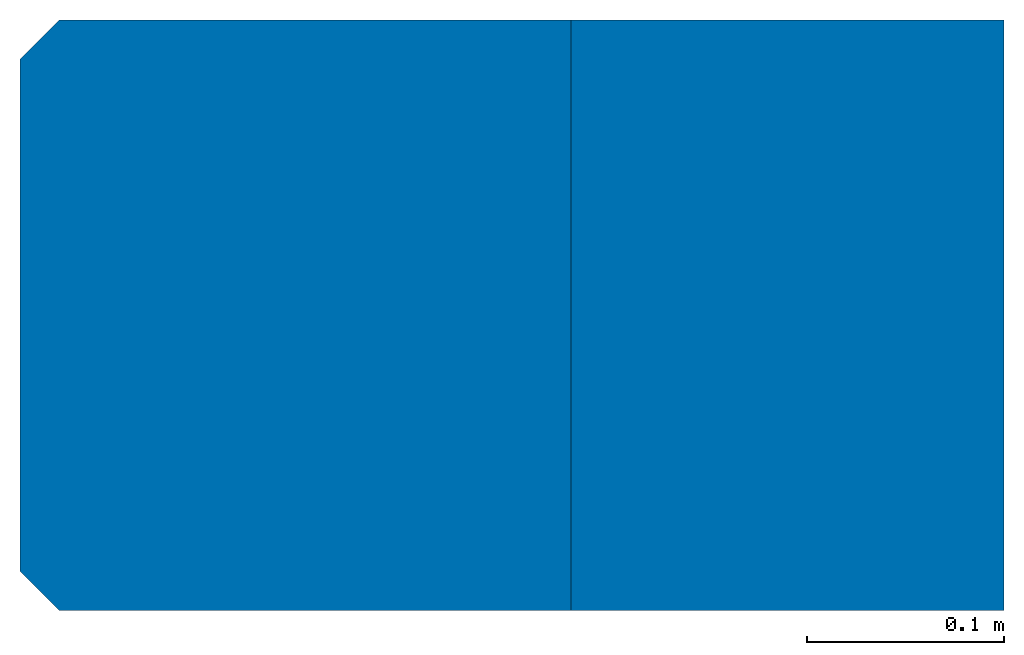
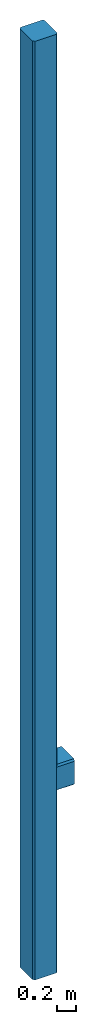
# One storey: 2 columns.
"""IFC2X3 building model written with IfcOpenShell, lengths in metres."""

from ifc_helpers import new_model, entity, si_unit, converted_unit, derived_unit, direction, frame, frame_2d, origin, place, context, subcontext, project, spatial, polyline, rectangle, outline, extrude, clip, halfspace, source, transform, mapped, type_object, type_shapes, element, save


model = new_model("IFC2X3")

# Units and contexts
model_context = context("Model", 3, precision=1e-05, world=origin(), true_north=direction((6.12303176911189e-17, 1.0)))
body_context = subcontext(model_context, "Body", "Model", "MODEL_VIEW")
ifc_project = project(units=[si_unit("LENGTHUNIT", "METRE"), converted_unit("AREAUNIT", "SQUARE FOOT", entity("IfcRatioMeasure", 0.09290304), si_unit("AREAUNIT", "SQUARE_METRE"), dimensions=[2, 0, 0, 0, 0, 0, 0]), converted_unit("VOLUMEUNIT", "CUBIC FOOT", entity("IfcRatioMeasure", 0.028316846592), si_unit("VOLUMEUNIT", "CUBIC_METRE"), dimensions=[3, 0, 0, 0, 0, 0, 0]), converted_unit("PLANEANGLEUNIT", "DEGREE", entity("IfcRatioMeasure", 0.0174532925199433), si_unit("PLANEANGLEUNIT", "RADIAN"), dimensions=[0, 0, 0, 0, 0, 0, 0]), si_unit("MASSUNIT", "GRAM", prefix="KILO"), derived_unit("MASSDENSITYUNIT", [(si_unit("MASSUNIT", "GRAM", prefix="KILO"), 1), (si_unit("LENGTHUNIT", "METRE"), -3)]), si_unit("TIMEUNIT", "SECOND"), si_unit("FREQUENCYUNIT", "HERTZ"), si_unit("THERMODYNAMICTEMPERATUREUNIT", "DEGREE_CELSIUS"), derived_unit("THERMALTRANSMITTANCEUNIT", [(si_unit("MASSUNIT", "GRAM", prefix="KILO"), 1), (si_unit("THERMODYNAMICTEMPERATUREUNIT", "KELVIN"), -1), (si_unit("TIMEUNIT", "SECOND"), -3)]), derived_unit("VOLUMETRICFLOWRATEUNIT", [(si_unit("LENGTHUNIT", "METRE"), 3), (si_unit("TIMEUNIT", "SECOND"), -1)]), si_unit("ELECTRICCURRENTUNIT", "AMPERE"), si_unit("ELECTRICVOLTAGEUNIT", "VOLT"), si_unit("POWERUNIT", "WATT"), si_unit("FORCEUNIT", "NEWTON"), si_unit("ILLUMINANCEUNIT", "LUX"), si_unit("LUMINOUSFLUXUNIT", "LUMEN"), si_unit("LUMINOUSINTENSITYUNIT", "CANDELA"), derived_unit("USERDEFINED", [(si_unit("MASSUNIT", "GRAM", prefix="KILO"), -1), (si_unit("LENGTHUNIT", "METRE"), -2), (si_unit("TIMEUNIT", "SECOND"), 3), (si_unit("LUMINOUSFLUXUNIT", "LUMEN"), 1)]), derived_unit("LINEARVELOCITYUNIT", [(si_unit("LENGTHUNIT", "METRE"), 1), (si_unit("TIMEUNIT", "SECOND"), -1)]), si_unit("PRESSUREUNIT", "PASCAL"), derived_unit("USERDEFINED", [(si_unit("LENGTHUNIT", "METRE"), -2), (si_unit("MASSUNIT", "GRAM", prefix="KILO"), 1), (si_unit("TIMEUNIT", "SECOND"), -2)])], contexts=[model_context])

# Site, building, storey
site_placement = place(None, origin())
site = spatial("IfcSite", under=ifc_project, at=site_placement, CompositionType="ELEMENT")
building_placement = place(site_placement, origin())
building = spatial("IfcBuilding", under=site, at=building_placement, CompositionType="ELEMENT")
storey_placement = place(building_placement, origin())
storey = spatial("IfcBuildingStorey", under=building, at=storey_placement, Name="Level 1", CompositionType="ELEMENT", Elevation=0.0)

# Columns
column_type_1 = type_object("IfcColumnType", Name="Structural Columns 1", PredefinedType="COLUMN")
shared_shape_1 = source(origin(), body_context, "Body", "Clipping", [
    clip(clip(clip(clip(extrude(rectangle(XDim=0.22, YDim=0.299999999999999, at=frame_2d((0.0, 6.93889390390723e-17), x_axis=(1.0, 0.0))), frame((0.240000000000001, 0.0, 2.32000000000001)), (0.0, 0.0, 1.0), 0.33), halfspace(frame((0.350000000000001, -0.15, 2.34000000000001), z_axis=(0.0, -0.707106781186547, -0.707106781186548), x_axis=(1.0, 0.0, 0.0)), False)), halfspace(frame((0.350000000000001, 0.129999999999999, 2.32000000000001), z_axis=(0.0, 0.707106781186551, -0.707106781186545), x_axis=(1.0, 0.0, 0.0)), False)), halfspace(frame((0.350000000000001, 0.149999999999999, 2.63), z_axis=(0.0, 0.707106781186552, 0.707106781186543), x_axis=(1.0, 0.0, 0.0)), False)), halfspace(frame((0.350000000000001, -0.13, 2.65000000000001), z_axis=(0.0, -0.707106781186545, 0.707106781186551), x_axis=(1.0, 0.0, 0.0)), False)),
])
type_shapes(column_type_1, [shared_shape_1])
column_1_placement = place(storey_placement, origin())
element("IfcColumn", 1, at=column_1_placement, inside=storey, type_object=column_type_1, Name="Structural Columns 1:Structural Columns 1", ObjectType="Structural Columns 1", context=body_context, shape_type="MappedRepresentation", body=[
    mapped(shared_shape_1, transform((0.0, 0.0, 0.0), scale=1.0)),
])
column_type_2 = type_object("IfcColumnType", Name="Structural Columns 1", PredefinedType="COLUMN")
shared_shape_2 = source(origin(), body_context, "Body", "SweptSolid", [
    extrude(outline(polyline([(-0.13, -0.15), (0.129999999999999, -0.15), (0.149999999999999, -0.13), (0.15, 0.13), (0.13, 0.15), (-0.129999999999999, 0.15), (-0.149999999999999, 0.13), (-0.15, -0.13), (-0.13, -0.15)])), frame((0.0, 0.0, 0.0), z_axis=(0.0, 0.0, 1.0), x_axis=(0.0, -1.0, 0.0)), (0.0, 0.0, 1.0), 12.0),
])
type_shapes(column_type_2, [shared_shape_2])
column_2_placement = place(storey_placement, origin())
element("IfcColumn", 2, at=column_2_placement, inside=storey, type_object=column_type_2, Name="Structural Columns 2:Structural Columns 1", ObjectType="Structural Columns 1", context=body_context, shape_type="MappedRepresentation", body=[
    mapped(shared_shape_2, transform((0.0, 0.0, 0.0), scale=1.0)),
])

save(model, "model.ifc")
